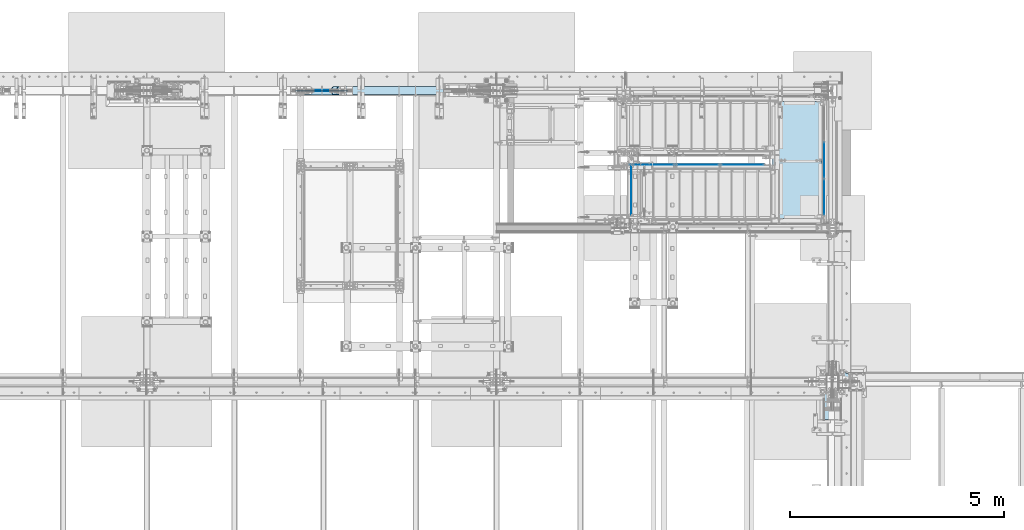
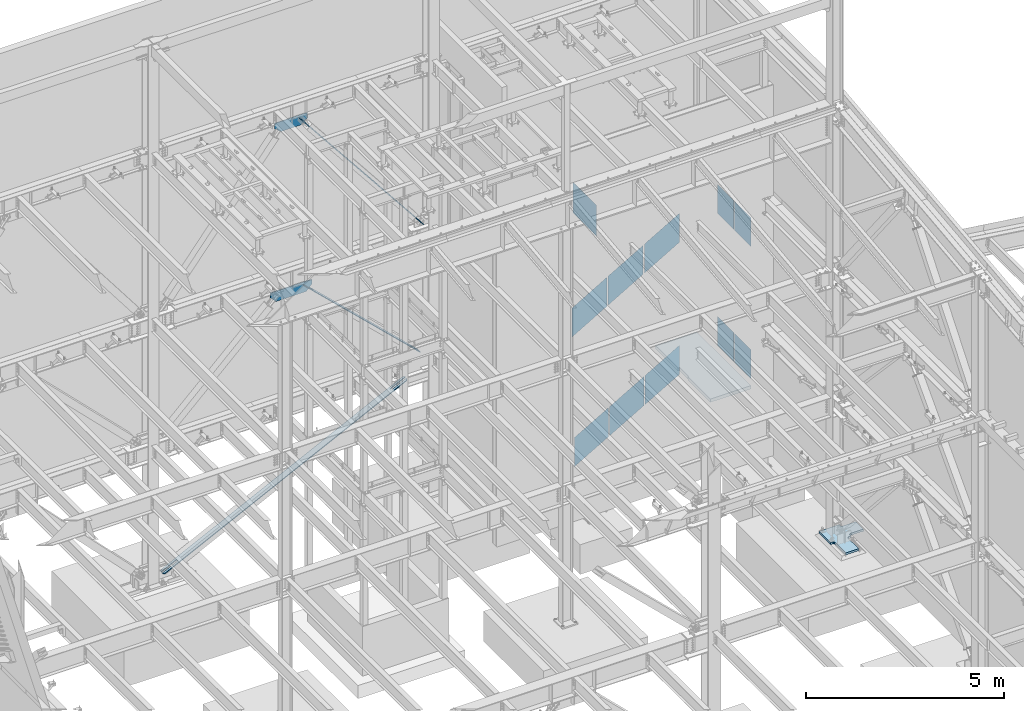
# One storey, part 981 of 1179: 17 plates, 1 slab, 12 elements without a shape of their own.
"""IFC2X3 building model written with IfcOpenShell, lengths in millimetres."""

from ifc_helpers import new_model, si_unit, frame, origin_with_axes, place, context, subcontext, project, spatial, faceted_brep, material, type_object, element, aggregate, save


model = new_model("IFC2X3")

# Units and contexts
model_context = context("Model", 3, precision=1e-05, world=origin_with_axes())
body_context = subcontext(model_context, "Body", "Model", "MODEL_VIEW")
ifc_project = project(units=[si_unit("LENGTHUNIT", "METRE", prefix="MILLI"), si_unit("AREAUNIT", "SQUARE_METRE"), si_unit("VOLUMEUNIT", "CUBIC_METRE"), si_unit("MASSUNIT", "GRAM", prefix="KILO"), si_unit("TIMEUNIT", "SECOND"), si_unit("PLANEANGLEUNIT", "RADIAN"), si_unit("SOLIDANGLEUNIT", "STERADIAN"), si_unit("THERMODYNAMICTEMPERATUREUNIT", "DEGREE_CELSIUS"), si_unit("LUMINOUSINTENSITYUNIT", "LUMEN")], contexts=[model_context])

# Site, building, storey
site_placement = place(None, origin_with_axes())
site = spatial("IfcSite", under=ifc_project, at=site_placement, CompositionType="ELEMENT")
building_placement = place(site_placement, origin_with_axes())
building = spatial("IfcBuilding", under=site, at=building_placement, Name="Undefined", CompositionType="ELEMENT")
storey_placement = place(building_placement, origin_with_axes())
storey = spatial("IfcBuildingStorey", under=building, at=storey_placement, Name="Undefined", CompositionType="ELEMENT", Elevation=0.0)

# Assembly, plates
assembly_1_placement = place(storey_placement, origin_with_axes())
assembly_1 = element("IfcElementAssembly", 1, at=assembly_1_placement, inside=storey, Name="GUARDRAIL", AssemblyPlace="NOTDEFINED", PredefinedType="RIGID_FRAME")
ifc_material_1 = material(Name="STEEL/BUY-OUT")
plate_type_1 = type_object("IfcPlateType", PredefinedType="NOTDEFINED")
plate_1_placement = place(assembly_1_placement, frame((21708.9301043003, 39471.6001653905, 2492.38988525828), z_axis=(1.0, 0.0, 0.0), x_axis=(0.0, 0.0, -1.0)))
plate_1 = element("IfcPlate", 2, at=plate_1_placement, type_object=plate_type_1, material=ifc_material_1, Name="PERFORATED_PANEL", context=body_context, shape_type="Brep", body=[
    faceted_brep([(0.0, -0.794000000001688, 0.0), (-576.384644370934, -0.794000000001688, 995.494718134461), (-576.384644370934, 0.794000000001688, 995.494718134461), (0.0, 0.794000000001688, 0.0), (321.642281769467, -0.794000000001688, 995.494820376709), (321.642281769467, 0.794000000001688, 995.494820376709), (898.027021117099, -0.794000000001688, 2.94676283374429e-10), (898.027021117099, 0.794000000001688, 2.94676283374429e-10)], [[[0, 1, 2, 3]], [[1, 4, 5, 2]], [[4, 6, 7, 5]], [[6, 0, 3, 7]], [[5, 7, 3, 2]], [[6, 4, 1, 0]]]),
])
plate_2_placement = place(assembly_1_placement, frame((20674.9384751372, 39471.6001653905, 1893.71591229504), z_axis=(1.0, 0.0, 0.0), x_axis=(0.0, 0.0, -1.0)))
plate_2 = element("IfcPlate", 3, at=plate_2_placement, type_object=plate_type_1, material=ifc_material_1, Name="PERFORATED_PANEL", context=body_context, shape_type="Brep", body=[
    faceted_brep([(0.0, -0.794000000001688, 0.0), (-576.384644370934, -0.794000000001688, 995.494718134461), (-576.384644370934, 0.794000000001688, 995.494718134461), (0.0, 0.794000000001688, 0.0), (321.642281769467, -0.794000000001688, 995.494820376709), (321.642281769467, 0.794000000001688, 995.494820376709), (898.027021117099, -0.794000000001688, 2.94676283374429e-10), (898.027021117099, 0.794000000001688, 2.94676283374429e-10)], [[[0, 1, 2, 3]], [[1, 4, 5, 2]], [[4, 6, 7, 5]], [[6, 0, 3, 7]], [[5, 7, 3, 2]], [[6, 4, 1, 0]]]),
])
plate_3_placement = place(assembly_1_placement, frame((19640.9468459742, 39471.6001653905, 1295.0419393318), z_axis=(1.0, 0.0, 0.0), x_axis=(0.0, 0.0, -1.0)))
plate_3 = element("IfcPlate", 4, at=plate_3_placement, type_object=plate_type_1, material=ifc_material_1, Name="PERFORATED_PANEL", context=body_context, shape_type="Brep", body=[
    faceted_brep([(0.0, -0.794000000001688, 0.0), (-576.384644370934, -0.794000000001688, 995.494718134461), (-576.384644370934, 0.794000000001688, 995.494718134461), (0.0, 0.794000000001688, 0.0), (321.642281769467, -0.794000000001688, 995.494820376709), (321.642281769467, 0.794000000001688, 995.494820376709), (898.027021117099, -0.794000000001688, 2.94676283374429e-10), (898.027021117099, 0.794000000001688, 2.94676283374429e-10)], [[[0, 1, 2, 3]], [[1, 4, 5, 2]], [[4, 6, 7, 5]], [[6, 0, 3, 7]], [[5, 7, 3, 2]], [[6, 4, 1, 0]]]),
])
aggregate(assembly_1, [plate_1, plate_2, plate_3])

assembly_2_placement = place(storey_placement, origin_with_axes())
assembly_2 = element("IfcElementAssembly", 5, at=assembly_2_placement, inside=storey, Name="GUARDRAIL", AssemblyPlace="NOTDEFINED", PredefinedType="RIGID_FRAME")
plate_type_2 = type_object("IfcPlateType", PredefinedType="NOTDEFINED")
plate_4_placement = place(assembly_2_placement, frame((21685.1707308262, 39471.6001646336, 6547.03132275248), z_axis=(1.0, 0.0, 0.0), x_axis=(0.0, 0.0, -1.0)))
plate_4 = element("IfcPlate", 6, at=plate_4_placement, type_object=plate_type_2, material=ifc_material_1, Name="PERFORATED_PANEL", context=body_context, shape_type="Brep", body=[
    faceted_brep([(0.0, -0.794000000001688, 0.0), (-594.365344393423, -0.794000000001688, 1018.91156588399), (-594.365344393423, 0.794000000001688, 1018.91156588399), (0.0, 0.794000000001688, 0.0), (302.657467626193, -0.794000000001688, 1018.91160558301), (302.657467626193, 0.794000000001688, 1018.91160558301), (897.022917306022, -0.794000000001688, 9.60426405072212e-10), (897.022917306022, 0.794000000001688, 9.60426405072212e-10)], [[[0, 1, 2, 3]], [[1, 4, 5, 2]], [[4, 6, 7, 5]], [[6, 0, 3, 7]], [[5, 7, 3, 2]], [[6, 4, 1, 0]]]),
])
plate_5_placement = place(assembly_2_placement, frame((20627.8957294995, 39471.6001646336, 5930.28757146853), z_axis=(1.0, 0.0, 0.0), x_axis=(0.0, 0.0, -1.0)))
plate_5 = element("IfcPlate", 7, at=plate_5_placement, type_object=plate_type_2, material=ifc_material_1, Name="PERFORATED_PANEL", context=body_context, shape_type="Brep", body=[
    faceted_brep([(0.0, -0.794000000001688, 0.0), (-594.365344393423, -0.794000000001688, 1018.91156588399), (-594.365344393423, 0.794000000001688, 1018.91156588399), (0.0, 0.794000000001688, 0.0), (302.657467626193, -0.794000000001688, 1018.91160558301), (302.657467626193, 0.794000000001688, 1018.91160558301), (897.022917306022, -0.794000000001688, 9.60426405072212e-10), (897.022917306022, 0.794000000001688, 9.60426405072212e-10)], [[[0, 1, 2, 3]], [[1, 4, 5, 2]], [[4, 6, 7, 5]], [[6, 0, 3, 7]], [[5, 7, 3, 2]], [[6, 4, 1, 0]]]),
])
plate_6_placement = place(assembly_2_placement, frame((19570.6207281727, 39471.6001646336, 5313.54382018459), z_axis=(1.0, 0.0, 0.0), x_axis=(0.0, 0.0, -1.0)))
plate_6 = element("IfcPlate", 8, at=plate_6_placement, type_object=plate_type_2, material=ifc_material_1, Name="PERFORATED_PANEL", context=body_context, shape_type="Brep", body=[
    faceted_brep([(0.0, -0.794000000001688, 0.0), (-594.365344393423, -0.794000000001688, 1018.91156588399), (-594.365344393423, 0.794000000001688, 1018.91156588399), (0.0, 0.794000000001688, 0.0), (302.657467626193, -0.794000000001688, 1018.91160558301), (302.657467626193, 0.794000000001688, 1018.91160558301), (897.022917306022, -0.794000000001688, 9.60426405072212e-10), (897.022917306022, 0.794000000001688, 9.60426405072212e-10)], [[[0, 1, 2, 3]], [[1, 4, 5, 2]], [[4, 6, 7, 5]], [[6, 0, 3, 7]], [[5, 7, 3, 2]], [[6, 4, 1, 0]]]),
])
aggregate(assembly_2, [plate_4, plate_5, plate_6])

assembly_3_placement = place(storey_placement, origin_with_axes())
assembly_3 = element("IfcElementAssembly", 9, at=assembly_3_placement, inside=storey, Name="GUARDRAIL", AssemblyPlace="NOTDEFINED", PredefinedType="RIGID_FRAME")
plate_type_3 = type_object("IfcPlateType", PredefinedType="NOTDEFINED")
plate_7_placement = place(assembly_3_placement, frame((24114.1251377853, 39989.7902699587, 7232.64066720411), z_axis=(0.0, -1.15660000010394e-05, -0.999999999933114), x_axis=(0.0, -0.999999999933114, 1.15659999997067e-05)))
plate_7 = element("IfcPlate", 10, at=plate_7_placement, type_object=plate_type_3, material=ifc_material_1, Name="PERFORATED_PANEL", context=body_context, shape_type="Brep", body=[
    faceted_brep([(0.0, -0.794000000001688, 0.0), (0.0038954056071816, -0.794000000001688, 895.340667845478), (0.0038954056071816, 0.794000000001688, 895.340667845478), (0.0, 0.794000000001688, 0.0), (827.213247312167, -0.794000000001688, 895.350236040999), (827.213247312167, 0.794000000001688, 895.350236040999), (827.223604344887, -0.794000000001688, 3.30965121975169e-09), (827.223604344887, 0.794000000001688, 3.30965121975169e-09)], [[[0, 1, 2, 3]], [[1, 4, 5, 2]], [[4, 6, 7, 5]], [[6, 0, 3, 7]], [[5, 7, 3, 2]], [[6, 4, 1, 0]]]),
])
plate_8_placement = place(assembly_3_placement, frame((24114.1251377853, 39124.0736032921, 7232.64066768633), z_axis=(0.0, -1.15660000010394e-05, -0.999999999933114), x_axis=(0.0, -0.999999999933114, 1.15659999997067e-05)))
plate_8 = element("IfcPlate", 11, at=plate_8_placement, type_object=plate_type_3, material=ifc_material_1, Name="PERFORATED_PANEL", context=body_context, shape_type="Brep", body=[
    faceted_brep([(0.0, -0.794000000001688, 0.0), (0.0038954056071816, -0.794000000001688, 895.340667845478), (0.0038954056071816, 0.794000000001688, 895.340667845478), (0.0, 0.794000000001688, 0.0), (827.213247312167, -0.794000000001688, 895.350236040999), (827.213247312167, 0.794000000001688, 895.350236040999), (827.223604344887, -0.794000000001688, 3.30965121975169e-09), (827.223604344887, 0.794000000001688, 3.30965121975169e-09)], [[[0, 1, 2, 3]], [[1, 4, 5, 2]], [[4, 6, 7, 5]], [[6, 0, 3, 7]], [[5, 7, 3, 2]], [[6, 4, 1, 0]]]),
])
aggregate(assembly_3, [plate_7, plate_8])

assembly_4_placement = place(storey_placement, origin_with_axes())
assembly_4 = element("IfcElementAssembly", 12, at=assembly_4_placement, inside=storey, Name="GUARDRAIL", AssemblyPlace="NOTDEFINED", PredefinedType="RIGID_FRAME")
plate_9_placement = place(assembly_4_placement, frame((24114.1251377853, 39989.7902699587, 3159.11566720411), z_axis=(0.0, -1.15660000010394e-05, -0.999999999933114), x_axis=(0.0, -0.999999999933114, 1.15659999997067e-05)))
plate_9 = element("IfcPlate", 13, at=plate_9_placement, type_object=plate_type_3, material=ifc_material_1, Name="PERFORATED_PANEL", context=body_context, shape_type="Brep", body=[
    faceted_brep([(0.0, -0.794000000001688, 0.0), (0.0038954056071816, -0.794000000001688, 895.340667845478), (0.0038954056071816, 0.794000000001688, 895.340667845478), (0.0, 0.794000000001688, 0.0), (827.213247312167, -0.794000000001688, 895.350236040999), (827.213247312167, 0.794000000001688, 895.350236040999), (827.223604344887, -0.794000000001688, 3.30965121975169e-09), (827.223604344887, 0.794000000001688, 3.30965121975169e-09)], [[[0, 1, 2, 3]], [[1, 4, 5, 2]], [[4, 6, 7, 5]], [[6, 0, 3, 7]], [[5, 7, 3, 2]], [[6, 4, 1, 0]]]),
])
plate_10_placement = place(assembly_4_placement, frame((24114.1251377853, 39124.0736032921, 3159.11566768633), z_axis=(0.0, -1.15660000010394e-05, -0.999999999933114), x_axis=(0.0, -0.999999999933114, 1.15659999997067e-05)))
plate_10 = element("IfcPlate", 14, at=plate_10_placement, type_object=plate_type_3, material=ifc_material_1, Name="PERFORATED_PANEL", context=body_context, shape_type="Brep", body=[
    faceted_brep([(0.0, -0.794000000001688, 0.0), (0.0038954056071816, -0.794000000001688, 895.340667845478), (0.0038954056071816, 0.794000000001688, 895.340667845478), (0.0, 0.794000000001688, 0.0), (827.213247312167, -0.794000000001688, 895.350236040999), (827.213247312167, 0.794000000001688, 895.350236040999), (827.223604344887, -0.794000000001688, 3.30965121975169e-09), (827.223604344887, 0.794000000001688, 3.30965121975169e-09)], [[[0, 1, 2, 3]], [[1, 4, 5, 2]], [[4, 6, 7, 5]], [[6, 0, 3, 7]], [[5, 7, 3, 2]], [[6, 4, 1, 0]]]),
])
aggregate(assembly_4, [plate_9, plate_10])

# Assembly, plate
assembly_5_placement = place(storey_placement, origin_with_axes())
assembly_5 = element("IfcElementAssembly", 15, at=assembly_5_placement, inside=storey, Name="GUARDRAIL", AssemblyPlace="NOTDEFINED", PredefinedType="RIGID_FRAME")
plate_type_4 = type_object("IfcPlateType", PredefinedType="NOTDEFINED")
plate_11_placement = place(assembly_5_placement, frame((19605.6249999015, 39465.264254057, 9188.44985025832), z_axis=(0.0, -7.22099999984494e-06, -0.999999999973929), x_axis=(0.0, -0.999999999973929, 7.22099999982526e-06)))
plate_11 = element("IfcPlate", 16, at=plate_11_placement, type_object=plate_type_4, material=ifc_material_1, Name="PERFORATED_PANEL", context=body_context, shape_type="Brep", body=[
    faceted_brep([(0.0, -0.794000000001688, 0.0), (0.00742035259463592, -0.794000000001688, 946.150000036158), (0.00742035259463592, 0.794000000001688, 946.150000036158), (0.0, 0.794000000001688, 0.0), (1174.75742353862, -0.794000000001688, 946.159568285531), (1174.75742353862, 0.794000000001688, 946.159568285531), (1174.76425558292, -0.794000000001688, -4.75665729027241e-09), (1174.76425558292, 0.794000000001688, -4.75665729027241e-09)], [[[0, 1, 2, 3]], [[1, 4, 5, 2]], [[4, 6, 7, 5]], [[6, 0, 3, 7]], [[5, 7, 3, 2]], [[6, 4, 1, 0]]]),
])
aggregate(assembly_5, [plate_11])

assembly_6_placement = place(storey_placement, origin_with_axes())
assembly_6 = element("IfcElementAssembly", 17, at=assembly_6_placement, inside=storey, Name="COLUMN", AssemblyPlace="NOTDEFINED", PredefinedType="RIGID_FRAME")
ifc_material_2 = material(Name="STEEL/A572-GR.50")
plate_type_5 = type_object("IfcPlateType", PredefinedType="NOTDEFINED")
plate_12_placement = place(assembly_6_placement, frame((25031.7000030515, 34683.7000940372, -247.65), z_axis=(0.0, -1.0, 0.0), x_axis=(-1.0, 0.0, 0.0)))
plate_12 = element("IfcPlate", 18, at=plate_12_placement, type_object=plate_type_5, material=ifc_material_2, context=body_context, shape_type="Brep", body=[
    faceted_brep([(482.600065908635, -31.75, 584.200100344351), (482.600065908635, 31.75, 584.200100344351), (431.799990844709, 31.75, 584.200097088869), (431.799990844731, -31.75, 584.200118713066), (502.040383980817, -31.75, 588.067020034701), (502.040383980817, 31.75, 588.067020034701), (518.521089853431, -31.75, 599.079075636611), (518.521089853431, 31.75, 599.079075636611), (529.533145455345, -31.75, 615.559781509226), (529.533145455345, 31.75, 615.559781509226), (533.400065145695, -31.75, 635.000099581412), (533.400065145695, 31.75, 635.000099581412), (533.400065145695, -31.75, 1168.40011255138), (533.400065145699, 31.75, 1168.40014280516), (431.799990133586, -31.75, 533.400118579135), (431.799990133586, 31.75, 533.400118579135), (427.93307025696, 31.75, 513.959800768396), (427.93307025696, -31.75, 513.959800768396), (416.921014655807, 31.75, 497.479095159972), (416.921014655807, -31.75, 497.479095159972), (400.44030893363, 31.75, 486.467039729047), (400.44030893363, -31.75, 486.467039729047), (380.999991082954, 31.75, 482.600120053219), (380.999991082954, -31.75, 482.600120053219), (0.0, 31.75, 482.600118654998), (0.0, -31.75, 482.600118654998), (0.0, 31.75, 101.600130861931), (0.0, -31.75, 101.600130861931), (380.999991082954, 31.75, 101.60012946371), (380.999991082954, -31.75, 101.60012946371), (400.44030893363, 31.75, 97.7332097878825), (400.44030893363, -31.75, 97.7332097878825), (416.921014655807, 31.75, 86.7211543569574), (416.921014655807, -31.75, 86.7211543569574), (427.93307025696, 31.75, 70.2404487485328), (427.93307025696, -31.75, 70.2404487485328), (431.799990133586, 31.75, 50.8001309377942), (431.799990133586, -31.75, 50.8001309377942), (431.799990844731, 31.75, 0.0), (431.799990844731, -31.75, 0.0), (1015.99996643063, 31.75, 0.0), (1015.99996643063, -31.75, 0.0), (1015.99996643063, 31.75, 584.200100344351), (1016.0000030515, -31.75, 584.200100344351), (965.199967193585, 31.75, 584.200100344351), (965.199967193585, -31.75, 584.200100344351), (945.759649121403, 31.75, 588.067020034701), (945.759649121403, -31.75, 588.067020034701), (929.278943248788, 31.75, 599.079075636611), (929.278943248788, -31.75, 599.079075636611), (918.266887646874, 31.75, 615.559781509226), (918.266887646874, -31.75, 615.559781509226), (914.399967956524, 31.75, 635.000099581412), (914.399967956524, -31.75, 635.000099581412), (914.39996795652, -31.75, 1168.40008184582), (914.39996795652, 31.75, 1168.40008184582)], [[[0, 1, 2, 3]], [[4, 5, 1, 0]], [[6, 7, 5, 4]], [[8, 9, 7, 6]], [[10, 11, 9, 8]], [[12, 13, 11, 10]], [[14, 15, 16, 17]], [[17, 16, 18, 19]], [[19, 18, 20, 21]], [[21, 20, 22, 23]], [[23, 22, 24, 25]], [[26, 27, 25, 24]], [[27, 26, 28, 29]], [[29, 28, 30, 31]], [[31, 30, 32, 33]], [[33, 32, 34, 35]], [[35, 34, 36, 37]], [[37, 36, 38, 39]], [[40, 41, 39, 38]], [[41, 40, 42, 43]], [[43, 42, 44, 45]], [[45, 44, 46, 47]], [[47, 46, 48, 49]], [[49, 48, 50, 51]], [[51, 50, 52, 53]], [[54, 53, 52, 55]], [[8, 6, 4, 0, 3, 14, 17, 19, 21, 23, 25, 27, 29, 31, 33, 35, 37, 39, 41, 43, 45, 47, 49, 51, 53, 54, 12, 10]], [[15, 14, 3, 2]], [[55, 52, 50, 48, 46, 44, 42, 40, 38, 36, 34, 32, 30, 28, 26, 24, 22, 20, 18, 16, 15, 2, 1, 5, 7, 9, 11, 13]], [[54, 55, 13, 12]]]),
])
aggregate(assembly_6, [plate_12])

# Assembly, slab
assembly_7_placement = place(storey_placement, origin_with_axes())
assembly_7 = element("IfcElementAssembly", 19, at=assembly_7_placement, inside=storey, Name="SLAB", AssemblyPlace="NOTDEFINED", PredefinedType="REINFORCEMENT_UNIT")
ifc_material_3 = material(Name="CONCRETE/3000")
slab_type = type_object("IfcSlabType", PredefinedType="NOTDEFINED")
slab_placement = place(assembly_7_placement, frame((24063.3250004143, 40944.8000001154, 2066.925), z_axis=(0.0, -1.0, 0.0), x_axis=(-1.0, 0.0, 0.0)))
slab = element("IfcSlab", 20, at=slab_placement, type_object=slab_type, material=ifc_material_3, Name="SLAB", PredefinedType="FLOOR", context=body_context, shape_type="Brep", body=[
    faceted_brep([(0.0, -50.8000000000002, 0.0), (0.0, -50.8000000000002, 2736.85000014063), (0.0, 50.8, 2736.85000014063), (0.0, 50.8, 0.0), (1184.27500000877, -50.8000000000002, 2736.84999999309), (1184.27500000877, 50.8, 2736.84999999309), (1184.27500000877, -50.8000000000002, 1600.20000013964), (1184.27500000877, 50.8, 1600.20000013964), (1158.87500000004, -50.8000000000002, 1600.20000013964), (1158.87500000004, 50.8, 1600.20000013964), (1158.87500000004, -50.8000000000002, 1143.00000009441), (1158.87500000004, 50.8, 1143.00000009441), (1203.32500016462, -50.8000000000002, 1143.00000009441), (1203.32500016462, 50.8, 1143.00000009441), (1203.32500016462, -50.8000000000002, 7.27595761418343e-12), (1203.32500016462, 50.8, 7.27595761418343e-12)], [[[0, 1, 2, 3]], [[1, 4, 5, 2]], [[4, 6, 7, 5]], [[6, 8, 9, 7]], [[8, 10, 11, 9]], [[10, 12, 13, 11]], [[12, 14, 15, 13]], [[14, 0, 3, 15]], [[5, 7, 9, 11, 13, 15, 3, 2]], [[14, 12, 10, 8, 6, 4, 1, 0]]]),
])
aggregate(assembly_7, [slab])

# Assembly, plate
assembly_8_placement = place(storey_placement, origin_with_axes())
assembly_8 = element("IfcElementAssembly", 21, at=assembly_8_placement, inside=storey, Name="BEAM", AssemblyPlace="NOTDEFINED", PredefinedType="RIGID_FRAME")
plate_type_6 = type_object("IfcPlateType", PredefinedType="NOTDEFINED")
plate_13_placement = place(assembly_8_placement, frame((11764.3671875, 41198.8, 7324.73402788818), z_axis=(1.0, 0.0, 0.0), x_axis=(0.0, 0.0, 1.0)))
plate_13 = element("IfcPlate", 22, at=plate_13_placement, type_object=plate_type_6, material=ifc_material_2, Name="PLATE", context=body_context, shape_type="Brep", body=[
    faceted_brep([(0.0, -12.7, 0.0), (-172.090129871724, -12.6999999999971, 164.607950508971), (-172.090129871724, 12.6999999999971, 164.607950508971), (0.0, 12.7, 0.0), (-172.090129716618, -12.6999999999971, 611.782812579324), (-172.090129716618, 12.6999999999971, 611.782812579324), (-172.090129565917, -12.6999999999971, 1046.25767271874), (-172.090129565917, 12.6999999999971, 1046.25767271874), (-0.0110362184805126, -12.6999999999971, 1210.85506668614), (-0.0110362184805126, 12.6999999999971, 1210.85506668614), (139.690972111818, -12.6999999999971, 1210.865625), (139.690972111818, 12.6999999999971, 1210.865625), (139.690974097157, -12.6999999999971, 0.0), (139.690974097157, 12.6999999999971, 0.0)], [[[0, 1, 2, 3]], [[1, 4, 5, 2]], [[4, 6, 7, 5]], [[6, 8, 9, 7]], [[8, 10, 11, 9]], [[10, 12, 13, 11]], [[12, 0, 3, 13]], [[5, 7, 9, 11, 13, 3, 2]], [[12, 10, 8, 6, 4, 1, 0]]]),
])
aggregate(assembly_8, [plate_13])

assembly_9_placement = place(storey_placement, origin_with_axes())
assembly_9 = element("IfcElementAssembly", 23, at=assembly_9_placement, inside=storey, Name="BEAM", AssemblyPlace="NOTDEFINED", PredefinedType="RIGID_FRAME")
plate_type_7 = type_object("IfcPlateType", PredefinedType="NOTDEFINED")
plate_14_placement = place(assembly_9_placement, frame((11893.55, 41198.8, 12487.3898755525), z_axis=(1.0, 0.0, 0.0), x_axis=(0.0, 0.0, 1.0)))
plate_14 = element("IfcPlate", 24, at=plate_14_placement, type_object=plate_type_7, material=ifc_material_2, Name="PLATE", context=body_context, shape_type="Brep", body=[
    faceted_brep([(0.0, -9.52499999999964, 0.0), (-148.137543633437, -9.52500000000146, 194.10005285674), (-148.137543633437, 9.52500000000146, 194.10005285674), (0.0, 9.52499999999964, 0.0), (-148.137543633437, -9.52500000000146, 482.599999999999), (-148.137543633437, 9.52500000000146, 482.599999999999), (-148.137543633437, -9.52500000000146, 758.399947143253), (-148.137543633437, 9.52500000000146, 758.399947143253), (6.76212039252277e-07, -9.52500000000146, 952.499999997119), (6.76212039252277e-07, 9.52500000000146, 952.499999997119), (164.985124447481, -9.52500000000146, 952.5), (164.985124447481, 9.52500000000146, 952.5), (164.985124447481, -9.52500000000146, 0.0), (164.985124447481, 9.52500000000146, 0.0)], [[[0, 1, 2, 3]], [[1, 4, 5, 2]], [[4, 6, 7, 5]], [[6, 8, 9, 7]], [[8, 10, 11, 9]], [[10, 12, 13, 11]], [[12, 0, 3, 13]], [[5, 7, 9, 11, 13, 3, 2]], [[12, 10, 8, 6, 4, 1, 0]]]),
])
aggregate(assembly_9, [plate_14])

assembly_10_placement = place(storey_placement, origin_with_axes())
assembly_10 = element("IfcElementAssembly", 25, at=assembly_10_placement, inside=storey, Name="CB", AssemblyPlace="NOTDEFINED", PredefinedType="RIGID_FRAME")
ifc_material_4 = material(Name="STEEL/A36")
plate_type_8 = type_object("IfcPlateType", PredefinedType="NOTDEFINED")
plate_15_placement = place(assembly_10_placement, frame((16210.8784020053, 41292.4625, 8051.58525633873), z_axis=(-0.622099916714249, 0.0, 0.782937860640373), x_axis=(0.0, -1.0, 0.0)))
plate_15 = element("IfcPlate", 26, at=plate_15_placement, type_object=plate_type_8, material=ifc_material_4, Name="CB", context=body_context, shape_type="Brep", body=[
    faceted_brep([(0.0, -7.93750000001455, 73.0250015258771), (0.0, -7.93750000132059, 5735.39272193171), (0.0, 7.93749999867941, 5735.39272193172), (0.0, 7.93749999998545, 73.0250015258807), (5.55869725451339, -7.93750000132786, 5763.3381801641), (5.55869725451339, 7.93749999867578, 5763.33818016411), (21.3885277507725, -7.9375000013315, 5787.02919570682), (21.3885277507725, 7.9374999986685, 5787.02919570683), (45.0795432934901, -7.93750000133514, 5802.85902620308), (45.0795432934901, 7.93749999866486, 5802.85902620308), (73.0250000000015, -7.93750000133514, 5808.41772345759), (73.0250000000015, 7.93749999866486, 5808.4177234576), (73.0250000000015, -7.93750000123691, 5386.83598265928), (73.0250000000015, 7.93749999875945, 5386.83598265929), (114.299999999996, -7.93750000123691, 5386.83598265928), (114.299999999996, 7.93749999875945, 5386.83598265929), (114.299998474118, -7.93750000133514, 5808.41772345759), (114.299998474118, 7.93749999866486, 5808.4177234576), (142.245456706507, -7.93750000133514, 5802.85902620308), (142.245456706507, 7.93749999866486, 5802.85902620308), (165.936472249225, -7.9375000013315, 5787.02919570682), (165.936472249225, 7.9374999986685, 5787.02919570683), (181.766302745484, -7.93750000132786, 5763.3381801641), (181.766302745484, 7.93749999867578, 5763.33818016411), (187.324999999997, -7.93750000132059, 5735.39272193171), (187.324999999997, 7.93749999867941, 5735.39272193172), (187.324999999997, -7.93750000001455, 73.0250015258771), (187.324999999997, 7.93749999998545, 73.0250015258807), (181.766302745484, -7.93750000000728, 45.0795432934874), (181.766302745484, 7.93749999999272, 45.079543293491), (165.936472249225, -7.93750000000364, 21.3885277507707), (165.936472249225, 7.93749999999636, 21.3885277507743), (142.245456706507, -7.9375, 5.55869725451157), (142.245456706507, 7.9375, 5.55869725451521), (114.299999999996, -7.9375, -9.09494701772928e-13), (114.299999999996, 7.9375, 2.72848410531878e-12), (114.299999999996, -7.93750000009459, 421.581740798303), (114.299999999996, 7.93749999990541, 421.581740798307), (73.0250000000015, -7.93750000009459, 421.581740798303), (73.0250000000015, 7.93749999990541, 421.581740798307), (73.0249996185303, -7.9375, 0.0), (73.0249996185303, 7.9375, 0.0), (45.0795432934901, -7.9375, 5.55869725451157), (45.0795432934901, 7.9375, 5.55869725451521), (21.3885277507725, -7.93750000000364, 21.3885277507707), (21.3885277507725, 7.93749999999636, 21.3885277507743), (5.55869725451339, -7.93750000000728, 45.0795432934874), (5.55869725451339, 7.93749999999272, 45.079543293491)], [[[0, 1, 2, 3]], [[1, 4, 5, 2]], [[4, 6, 7, 5]], [[6, 8, 9, 7]], [[8, 10, 11, 9]], [[10, 12, 13, 11]], [[12, 14, 15, 13]], [[14, 16, 17, 15]], [[16, 18, 19, 17]], [[18, 20, 21, 19]], [[20, 22, 23, 21]], [[22, 24, 25, 23]], [[24, 26, 27, 25]], [[26, 28, 29, 27]], [[28, 30, 31, 29]], [[30, 32, 33, 31]], [[32, 34, 35, 33]], [[34, 36, 37, 35]], [[36, 38, 39, 37]], [[38, 40, 41, 39]], [[40, 42, 43, 41]], [[42, 44, 45, 43]], [[44, 46, 47, 45]], [[46, 0, 3, 47]], [[5, 7, 9, 11, 13, 15, 17, 19, 21, 23, 25, 27, 29, 31, 33, 35, 37, 39, 41, 43, 45, 47, 3, 2]], [[46, 44, 42, 40, 38, 36, 34, 32, 30, 28, 26, 24, 22, 20, 18, 16, 14, 12, 10, 8, 6, 4, 1, 0]]]),
])
aggregate(assembly_10, [plate_15])

assembly_11_placement = place(storey_placement, origin_with_axes())
assembly_11 = element("IfcElementAssembly", 27, at=assembly_11_placement, inside=storey, Name="CB", AssemblyPlace="NOTDEFINED", PredefinedType="RIGID_FRAME")
plate_type_9 = type_object("IfcPlateType", PredefinedType="NOTDEFINED")
plate_16_placement = place(assembly_11_placement, frame((16123.5872838209, 41292.4625, 4148.48335911021), z_axis=(-0.722641857060828, 0.0, 0.691222646058184), x_axis=(0.0, -1.0, 0.0)))
plate_16 = element("IfcPlate", 28, at=plate_16_placement, type_object=plate_type_9, material=ifc_material_4, Name="CB", context=body_context, shape_type="Brep", body=[
    faceted_brep([(0.0, -9.52500000000691, 71.4375), (0.0, -9.52500000013788, 4636.62335586428), (0.0, 9.52499999987231, 4636.62335586427), (0.0, 9.52500000000327, 71.4374999999909), (5.43785589622712, -9.52500000014152, 4663.96130356386), (5.43785589622712, 9.52499999987049, 4663.96130356384), (20.9235593189878, -9.5250000001397, 4687.13729654529), (20.9235593189878, 9.52499999986867, 4687.13729654527), (44.0995523004167, -9.5250000001397, 4702.62299996805), (44.0995523004167, 9.52499999986867, 4702.62299996804), (71.4375, -9.52500000014152, 4708.06085586427), (71.4375, 9.52499999986867, 4708.06085586426), (71.4375, -9.5250000001306, 4286.47911506541), (71.4375, 9.5249999998814, 4286.4791150654), (115.887499999997, -9.5250000001306, 4286.47911506541), (115.887499999997, 9.5249999998814, 4286.4791150654), (115.887499999997, -9.52500000014152, 4708.06085586427), (115.887499999997, 9.52499999986867, 4708.06085586426), (143.22544769958, -9.5250000001397, 4702.62299996805), (143.22544769958, 9.52499999986867, 4702.62299996804), (166.401440681009, -9.5250000001397, 4687.13729654529), (166.401440681009, 9.52499999986867, 4687.13729654527), (181.88714410377, -9.52500000014152, 4663.96130356386), (181.88714410377, 9.52499999987049, 4663.96130356384), (187.324999999997, -9.52500000013788, 4636.62335586428), (187.324999999997, 9.52499999987231, 4636.62335586427), (187.324999999997, -9.52500000000691, 71.4375), (187.324999999997, 9.52500000000327, 71.4374999999909), (181.88714410377, -9.52500000000691, 44.0995523004203), (181.88714410377, 9.52500000000509, 44.0995523004112), (166.401440681009, -9.52500000000691, 20.9235593189915), (166.401440681009, 9.52500000000509, 20.9235593189787), (143.22544769958, -9.52500000000327, 5.43785589623076), (143.22544769958, 9.52500000000509, 5.43785589621621), (115.887499999997, -9.52500000000509, 5.45696821063757e-12), (115.887499999997, 9.52500000000691, -7.27595761418343e-12), (115.887499999997, -9.52500000001783, 421.581740798863), (115.887499999997, 9.52499999999418, 421.581740798851), (71.4375, -9.52500000001783, 421.581740798863), (71.4375, 9.52499999999418, 421.581740798851), (71.4375, -9.52500000000509, 5.45696821063757e-12), (71.4375, 9.52500000000691, -7.27595761418343e-12), (44.0995523004167, -9.52500000000327, 5.43785589623076), (44.0995523004167, 9.52500000000509, 5.43785589621621), (20.9235593189878, -9.52500000000691, 20.9235593189915), (20.9235593189878, 9.52500000000509, 20.9235593189787), (5.43785589622712, -9.52500000000691, 44.0995523004203), (5.43785589622712, 9.52500000000509, 44.0995523004112)], [[[0, 1, 2, 3]], [[1, 4, 5, 2]], [[4, 6, 7, 5]], [[6, 8, 9, 7]], [[8, 10, 11, 9]], [[10, 12, 13, 11]], [[12, 14, 15, 13]], [[14, 16, 17, 15]], [[16, 18, 19, 17]], [[18, 20, 21, 19]], [[20, 22, 23, 21]], [[22, 24, 25, 23]], [[24, 26, 27, 25]], [[26, 28, 29, 27]], [[28, 30, 31, 29]], [[30, 32, 33, 31]], [[32, 34, 35, 33]], [[34, 36, 37, 35]], [[36, 38, 39, 37]], [[38, 40, 41, 39]], [[40, 42, 43, 41]], [[42, 44, 45, 43]], [[44, 46, 47, 45]], [[46, 0, 3, 47]], [[5, 7, 9, 11, 13, 15, 17, 19, 21, 23, 25, 27, 29, 31, 33, 35, 37, 39, 41, 43, 45, 47, 3, 2]], [[46, 44, 42, 40, 38, 36, 34, 32, 30, 28, 26, 24, 22, 20, 18, 16, 14, 12, 10, 8, 6, 4, 1, 0]]]),
])
aggregate(assembly_11, [plate_16])

assembly_12_placement = place(storey_placement, origin_with_axes())
assembly_12 = element("IfcElementAssembly", 29, at=assembly_12_placement, inside=storey, Name="CB", AssemblyPlace="NOTDEFINED", PredefinedType="RIGID_FRAME")
plate_type_10 = type_object("IfcPlateType", PredefinedType="NOTDEFINED")
plate_17_placement = place(assembly_12_placement, frame((8606.14016651373, 41101.9625, -54.8634696934607), z_axis=(0.896436455583732, 0.0, 0.443172292794209), x_axis=(0.0, 1.0, 0.0)))
plate_17 = element("IfcPlate", 30, at=plate_17_placement, type_object=plate_type_10, material=ifc_material_4, Name="CB", context=body_context, shape_type="Brep", body=[
    faceted_brep([(0.0, -12.6999999999871, 65.0875015258525), (0.0, -12.6999999980471, 7884.32109683731), (0.0, 12.7000000019589, 7884.3210968373), (0.0, 12.7000000000194, 65.0875015258407), (4.95449104381987, -12.6999999980412, 7909.22900532529), (4.95449104381987, 12.7000000019661, 7909.22900532528), (19.0636878264413, -12.6999999980362, 7930.34491053673), (19.0636878264413, 12.7000000019707, 7930.34491053671), (40.1795930378867, -12.6999999980326, 7944.45410731934), (40.1795930378867, 12.7000000019739, 7944.45410731932), (65.0875000000015, -12.6999999980303, 7949.40859836316), (65.0875000000015, 12.7000000019752, 7949.40859836315), (65.0875000000015, -12.6999999981545, 7449.74179916838), (65.0875000000015, 12.700000001852, 7449.74179916837), (128.587500000001, -12.6999999981545, 7449.74179916838), (128.587500000001, 12.700000001852, 7449.74179916837), (128.587498474124, -12.6999999980303, 7949.40859836316), (128.587498474124, 12.7000000019752, 7949.40859836315), (153.495406962116, -12.6999999980326, 7944.45410731934), (153.495406962116, 12.7000000019739, 7944.45410731932), (174.611312173562, -12.6999999980362, 7930.34491053673), (174.611312173562, 12.7000000019707, 7930.34491053671), (188.720508956183, -12.6999999980412, 7909.22900532529), (188.720508956183, 12.7000000019661, 7909.22900532528), (193.675000000003, -12.6999999980471, 7884.32109683731), (193.675000000003, 12.7000000019589, 7884.3210968373), (193.675000000003, -12.6999999999871, 65.0875015258525), (193.675000000003, 12.7000000000194, 65.0875015258407), (188.720508956183, -12.6999999999939, 40.1795930378748), (188.720508956183, 12.7000000000126, 40.179593037863), (174.611312173562, -12.6999999999985, 19.0636878264377), (174.611312173562, 12.7000000000075, 19.0636878264249), (153.495406962116, -12.7000000000016, 4.95449104382624), (153.495406962116, 12.7000000000044, 4.95449104381441), (128.587500000001, -12.7000000000035, 8.18545231595635e-12), (128.587500000001, 12.700000000003, -6.3664629124105e-12), (128.587500000001, -12.6999999998793, 499.666799194779), (128.587500000001, 12.7000000001267, 499.666799194767), (65.0875000000015, -12.6999999998793, 499.666799194779), (65.0875000000015, 12.7000000001267, 499.666799194767), (65.0875015258789, -12.7000000000035, 8.18545231595635e-12), (65.0875015258789, 12.700000000003, -6.3664629124105e-12), (40.1795930378867, -12.7000000000016, 4.95449104382624), (40.1795930378867, 12.7000000000044, 4.95449104381441), (19.0636878264413, -12.6999999999985, 19.0636878264377), (19.0636878264413, 12.7000000000075, 19.0636878264249), (4.95449104381987, -12.6999999999939, 40.1795930378748), (4.95449104381987, 12.7000000000126, 40.179593037863)], [[[0, 1, 2, 3]], [[1, 4, 5, 2]], [[4, 6, 7, 5]], [[6, 8, 9, 7]], [[8, 10, 11, 9]], [[10, 12, 13, 11]], [[12, 14, 15, 13]], [[14, 16, 17, 15]], [[16, 18, 19, 17]], [[18, 20, 21, 19]], [[20, 22, 23, 21]], [[22, 24, 25, 23]], [[24, 26, 27, 25]], [[26, 28, 29, 27]], [[28, 30, 31, 29]], [[30, 32, 33, 31]], [[32, 34, 35, 33]], [[34, 36, 37, 35]], [[36, 38, 39, 37]], [[38, 40, 41, 39]], [[40, 42, 43, 41]], [[42, 44, 45, 43]], [[44, 46, 47, 45]], [[46, 0, 3, 47]], [[5, 7, 9, 11, 13, 15, 17, 19, 21, 23, 25, 27, 29, 31, 33, 35, 37, 39, 41, 43, 45, 47, 3, 2]], [[46, 44, 42, 40, 38, 36, 34, 32, 30, 28, 26, 24, 22, 20, 18, 16, 14, 12, 10, 8, 6, 4, 1, 0]]]),
])
aggregate(assembly_12, [plate_17])

save(model, "model.ifc")
